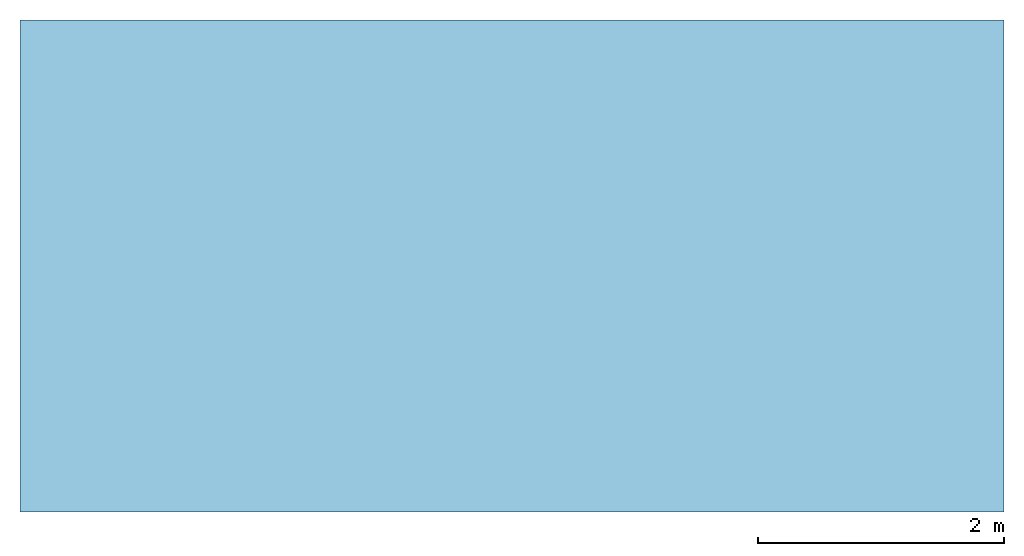
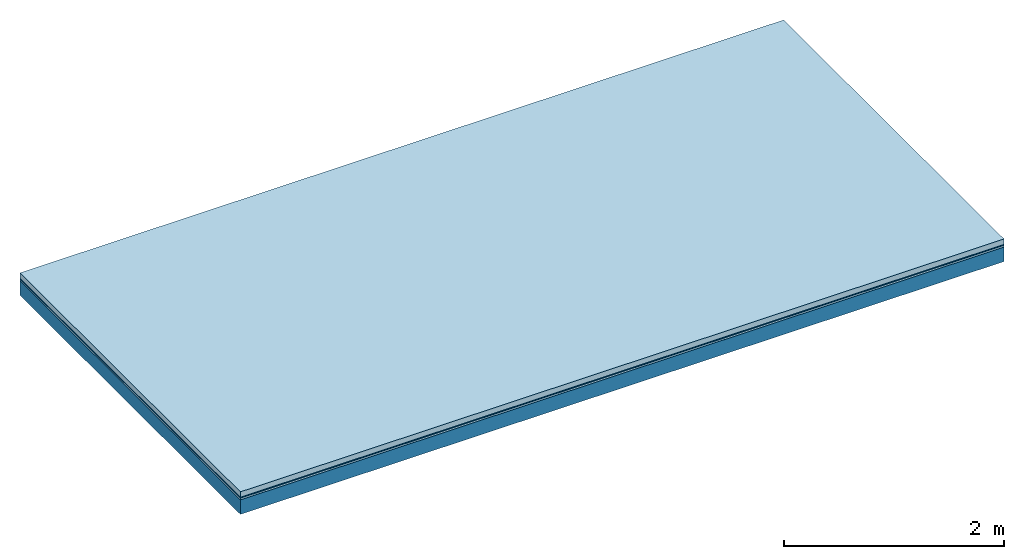
# One storey: 3 plates, 1 member, 1 element without a shape of its own.
"""IFC4 building model written with IfcOpenShell, lengths in metres."""

from ifc_helpers import new_model, si_unit, derived_unit, direction, frame, frame_2d, origin, origin_with_axes, place, context, project, spatial, rectangle, extrude, material, layer, layer_set, type_object, element, aggregate, save


model = new_model("IFC4")

# Units and contexts
plan_context = context("Plan", 3, precision=1e-05, world=origin(), true_north=direction((0.0, 1.0)))
model_context = context("Model", 3, precision=1e-05, world=origin(), true_north=direction((0.0, 1.0)))
ifc_project = project(units=[si_unit("LENGTHUNIT", "METRE"), derived_unit("SOUNDPRESSUREUNIT", [(si_unit("PRESSUREUNIT", "PASCAL", prefix="MICRO"), 0)]), si_unit("ENERGYUNIT", "JOULE", prefix="MEGA"), si_unit("MASSUNIT", "GRAM", prefix="KILO"), derived_unit("THERMALTRANSMITTANCEUNIT", [(si_unit("POWERUNIT", "WATT"), 1), (si_unit("AREAUNIT", "SQUARE_METRE"), -1), (si_unit("THERMODYNAMICTEMPERATUREUNIT", "KELVIN"), -1)]), derived_unit("AREADENSITYUNIT", [(si_unit("MASSUNIT", "GRAM", prefix="KILO"), 1), (si_unit("AREAUNIT", "SQUARE_METRE"), -1)]), derived_unit("USERDEFINED", [(si_unit("ENERGYUNIT", "JOULE", prefix="MEGA"), 1), (si_unit("AREAUNIT", "SQUARE_METRE"), -1)])], contexts=[plan_context, model_context])

# Site, building, storey
site = spatial("IfcSite", under=ifc_project)
building_placement = place(None, origin())
building = spatial("IfcBuilding", under=site, at=building_placement)
storey_placement = place(building_placement, origin())
storey = spatial("IfcBuildingStorey", under=building, at=storey_placement)

# Slab, member, plates
ifc_material_1 = material(Name="clay", Category="02.004")
ifc_layer_1 = layer(ifc_material_1, 0.06, Name="Use and protection layer 2")
ifc_material_2 = material(Name="Protective layer", Category="09.007")
ifc_layer_2 = layer(ifc_material_2, 0.01, Name="Use and protection layer 1")
ifc_material_3 = material(Name="Bituminous", Category="09.003")
ifc_layer_3 = layer(ifc_material_3, 0.02, Name="Seal")
ifc_material_4 = material(Name="no composite action")
ifc_layer_4 = layer(ifc_material_4, 0.0, Name="Bond")
ifc_layer_5 = layer(None, 0.16, Name="Support")
ifc_layer_set = layer_set([ifc_layer_1, ifc_layer_2, ifc_layer_3, ifc_layer_4, ifc_layer_5])
slab_type = type_object("IfcSlabType", Name="F0033", PredefinedType="NOTDEFINED", material=ifc_layer_set)
slab_placement = place(None, frame((0.0, 0.0, 0.0), z_axis=(0.0, 0.0, -1.0), x_axis=(1.0, 0.0, 0.0)))
slab = element("IfcSlab", 1, at=slab_placement, inside=storey, type_object=slab_type, material=ifc_layer_set, Name="Slab #1")
ifc_material_5 = material(Name="Solid timber panel")
member_placement = place(slab_placement, origin())
member = element("IfcMember", 2, at=member_placement, material=ifc_material_5, Name="Support", context=plan_context, shape_type="SweptSolid", body=[
    extrude(rectangle(XDim=1.0, YDim=0.16, at=frame_2d((0.5, 0.08), x_axis=(1.0, 0.0))), frame((0.0, 4.0, 0.09), z_axis=(0.0, -1.0, 0.0), x_axis=(1.0, 0.0, 0.0)), (0.0, 0.0, 1.0), 4.0),
    extrude(rectangle(XDim=1.0, YDim=0.16, at=frame_2d((0.5, 0.08), x_axis=(1.0, 0.0))), frame((1.0, 4.0, 0.09), z_axis=(0.0, -1.0, 0.0), x_axis=(1.0, 0.0, 0.0)), (0.0, 0.0, 1.0), 4.0),
    extrude(rectangle(XDim=1.0, YDim=0.16, at=frame_2d((0.5, 0.08), x_axis=(1.0, 0.0))), frame((2.0, 4.0, 0.09), z_axis=(0.0, -1.0, 0.0), x_axis=(1.0, 0.0, 0.0)), (0.0, 0.0, 1.0), 4.0),
    extrude(rectangle(XDim=1.0, YDim=0.16, at=frame_2d((0.5, 0.08), x_axis=(1.0, 0.0))), frame((3.0, 4.0, 0.09), z_axis=(0.0, -1.0, 0.0), x_axis=(1.0, 0.0, 0.0)), (0.0, 0.0, 1.0), 4.0),
    extrude(rectangle(XDim=1.0, YDim=0.16, at=frame_2d((0.5, 0.08), x_axis=(1.0, 0.0))), frame((4.0, 4.0, 0.09), z_axis=(0.0, -1.0, 0.0), x_axis=(1.0, 0.0, 0.0)), (0.0, 0.0, 1.0), 4.0),
    extrude(rectangle(XDim=1.0, YDim=0.16, at=frame_2d((0.5, 0.08), x_axis=(1.0, 0.0))), frame((5.0, 4.0, 0.09), z_axis=(0.0, -1.0, 0.0), x_axis=(1.0, 0.0, 0.0)), (0.0, 0.0, 1.0), 4.0),
    extrude(rectangle(XDim=1.0, YDim=0.16, at=frame_2d((0.5, 0.08), x_axis=(1.0, 0.0))), frame((6.0, 4.0, 0.09), z_axis=(0.0, -1.0, 0.0), x_axis=(1.0, 0.0, 0.0)), (0.0, 0.0, 1.0), 4.0),
    extrude(rectangle(XDim=1.0, YDim=0.16, at=frame_2d((0.5, 0.08), x_axis=(1.0, 0.0))), frame((7.0, 4.0, 0.09), z_axis=(0.0, -1.0, 0.0), x_axis=(1.0, 0.0, 0.0)), (0.0, 0.0, 1.0), 4.0),
])
plate_1_placement = place(slab_placement, origin())
plate_1 = element("IfcPlate", 3, at=plate_1_placement, material=ifc_material_1, Name="Use and protection layer 2", context=plan_context, shape_type="SweptSolid", body=[
    extrude(rectangle(XDim=8.0, YDim=4.0, at=frame_2d((4.0, 2.0), x_axis=(1.0, 0.0))), origin_with_axes(), (0.0, 0.0, 1.0), 0.06),
])
plate_2_placement = place(slab_placement, origin())
plate_2 = element("IfcPlate", 4, at=plate_2_placement, material=ifc_material_2, Name="Use and protection layer 1", context=plan_context, shape_type="SweptSolid", body=[
    extrude(rectangle(XDim=8.0, YDim=4.0, at=frame_2d((4.0, 2.0), x_axis=(1.0, 0.0))), frame((0.0, 0.0, 0.06), z_axis=(0.0, 0.0, 1.0), x_axis=(1.0, 0.0, 0.0)), (0.0, 0.0, 1.0), 0.01),
])
plate_3_placement = place(slab_placement, origin())
plate_3 = element("IfcPlate", 5, at=plate_3_placement, material=ifc_material_3, Name="Seal", context=plan_context, shape_type="SweptSolid", body=[
    extrude(rectangle(XDim=8.0, YDim=4.0, at=frame_2d((4.0, 2.0), x_axis=(1.0, 0.0))), frame((0.0, 0.0, 0.07), z_axis=(0.0, 0.0, 1.0), x_axis=(1.0, 0.0, 0.0)), (0.0, 0.0, 1.0), 0.02),
])
aggregate(slab, [plate_1, plate_2, plate_3, member])

save(model, "model.ifc")
